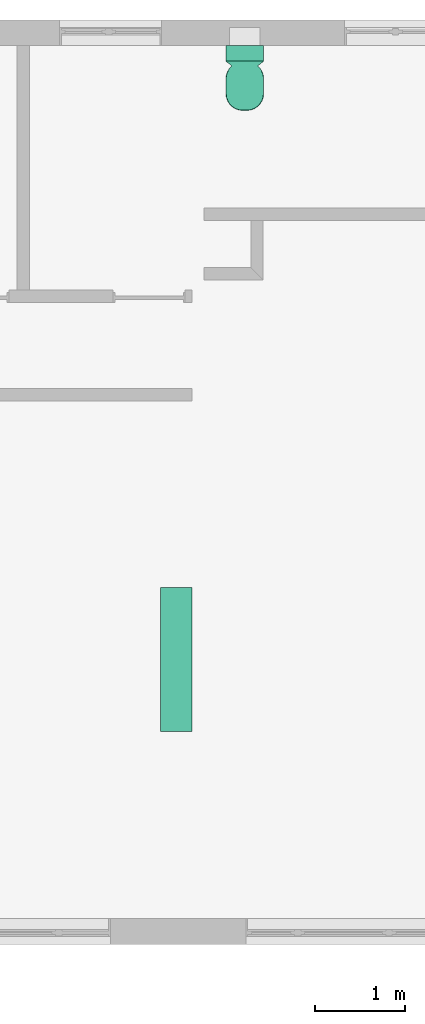
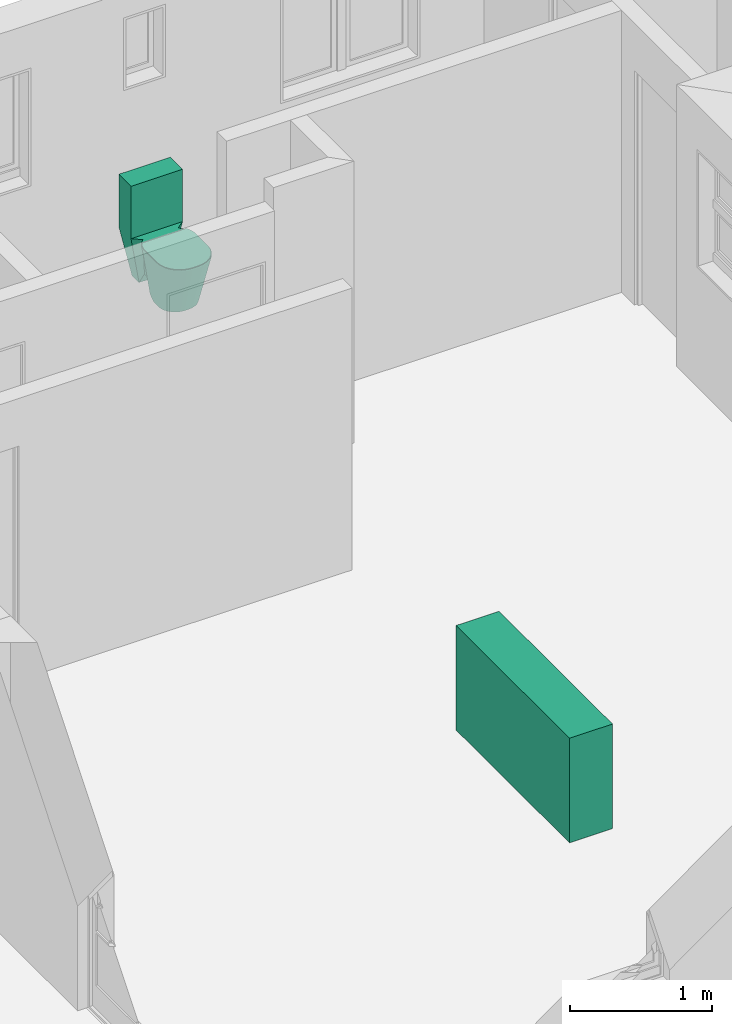
# One storey, part 15 of 15: 1 sanitary terminal, 1 space heater.
"""IFC4 building model written with IfcOpenShell, lengths in millimetres."""

from ifc_helpers import new_model, entity, si_unit, converted_unit, frame, origin_with_axes, origin_2d_with_axis, place, context, subcontext, project, spatial, polygons, source, transform, mapped, type_object, type_shapes, element, save


model = new_model("IFC4")

# Units and contexts
model_context = context("Model", 3, precision=1e-05, world=origin_with_axes())
plan_context = context("Plan", 2, precision=1e-05, world=origin_2d_with_axis())
body_context = subcontext(model_context, "Body", "Model", "MODEL_VIEW")
ifc_project = project(units=[si_unit("VOLUMEUNIT", "CUBIC_METRE"), si_unit("LENGTHUNIT", "METRE", prefix="MILLI"), converted_unit("PLANEANGLEUNIT", "degree", entity("IfcReal", 0.0174532925199433), si_unit("PLANEANGLEUNIT", "RADIAN"), dimensions=[0, 0, 0, 0, 0, 0, 0]), si_unit("AREAUNIT", "SQUARE_METRE")], contexts=[model_context, plan_context])

# Site, building, storey
site_placement = place(None, origin_with_axes())
site = spatial("IfcSite", under=ifc_project, at=site_placement)
building_placement = place(site_placement, origin_with_axes())
building = spatial("IfcBuilding", under=site, at=building_placement, Name="Building")
storey_placement = place(building_placement, origin_with_axes())
storey = spatial("IfcBuildingStorey", under=building, at=storey_placement, Name="EXISTING")

# Sanitary terminal
sanitary_terminal_type = type_object("IfcSanitaryTerminalType", Name="Toilet", PredefinedType="TOILETPAN")
shared_shape_1 = source(origin_with_axes(), body_context, "Body", "Tessellation", [
    polygons([(-123.31803894043, 324.464721679688, -214.999862670898), (-210.0, 360.0, 214.999984741211), (123.31803894043, 324.464721679688, -214.999862670898), (210.0, 360.0, 214.999984741211), (-123.31803894043, 223.359252929688, -214.999435424805), (-210.0, 187.826080322266, 214.999984741211), (123.31803894043, 223.359252929688, -214.999862670898), (210.0, 187.826080322266, 214.999984741211), (-154.309646606445, -91.084358215332, -214.999984741211), (210.0, -163.151611328125, 214.999984741211), (-210.0, -163.151611328125, 214.999984741211), (154.309646606445, -91.084358215332, -214.999984741211), (-143.305480957031, 135.49870300293, 214.999984741211), (104.407829284668, 180.682067871094, -121.331802368164), (-104.408195495605, 180.682083129883, -121.331802368164), (143.304977416992, 135.498718261719, 214.999984741211), (-16.6275787353516, -235.730102539062, -214.999984741211), (-154.309646606445, -98.0479965209961, -214.999984741211), (-47.264720916748, -232.278121948242, -214.999984741211), (-76.365592956543, -222.095291137695, -214.999984741211), (-102.470947265625, -205.692199707031, -214.999984741211), (-124.271766662598, -183.891403198242, -214.999984741211), (-140.674835205078, -157.786010742188, -214.999984741211), (-150.857681274414, -128.685165405273, -214.999984741211), (-210.0, -172.628433227539, 214.999984741211), (-22.6284408569336, -360.0, 214.999984741211), (-205.302200317383, -214.322555541992, 214.999984741211), (-191.444366455078, -253.925903320312, 214.999984741211), (-169.12141418457, -289.452728271484, 214.999984741211), (-139.452682495117, -319.121429443359, 214.999984741211), (-103.925910949707, -341.444396972656, 214.999984741211), (-64.3225326538086, -355.302185058594, 214.999984741211), (154.309646606445, -98.0479965209961, -214.999984741211), (16.627555847168, -235.730102539062, -214.999984741211), (150.857681274414, -128.685165405273, -214.999984741211), (140.674835205078, -157.786010742188, -214.999984741211), (124.271759033203, -183.891403198242, -214.999984741211), (102.470932006836, -205.692199707031, -214.999984741211), (76.3655776977539, -222.095291137695, -214.999984741211), (47.264705657959, -232.278121948242, -214.999984741211), (22.6284694671631, -360.0, 214.999984741211), (210.0, -172.628433227539, 214.999984741211), (64.3225555419922, -355.302185058594, 214.999984741211), (103.925918579102, -341.444396972656, 214.999984741211), (139.452697753906, -319.121429443359, 214.999984741211), (169.121429443359, -289.452728271484, 214.999984741211), (191.444366455078, -253.925903320312, 214.999984741211), (205.302200317383, -214.322555541992, 214.999984741211), (-154.309646606445, -36.9600563049316, -214.999984741211), (-104.70548248291, 142.322677612305, -121.334297180176), (-69.9907455444336, 83.1664428710938, -150.48860168457), (-151.592681884766, 18.9604740142822, -182.336196899414), (-145.59130859375, 40.6167221069336, -160.335861206055), (-133.410614013672, 62.7893905639648, -140.107452392578), (-122.13614654541, 84.3662490844727, -130.550598144531), (-114.744720458984, 104.265563964844, -126.247489929199), (-109.116271972656, 121.491508483887, -121.334510803223), (210.0, -1.09207618236542, 214.999984741211), (143.713348388672, 135.178298950195, 214.999984741211), (125.742744445801, 83.1651840209961, 214.999984741211), (208.338043212891, 18.9610080718994, 214.999984741211), (203.435562133789, 40.6166954040527, 214.999984741211), (195.538330078125, 62.7890930175781, 214.999984741211), (185.042404174805, 84.3663787841797, 214.999984741211), (172.474044799805, 104.266571044922, 214.999984741211), (158.463516235352, 121.491790771484, 214.999984741211), (-143.713516235352, 135.178527832031, 214.999984741211), (-210.0, -1.09206879138947, 214.999984741211), (-125.742744445801, 83.1651840209961, 214.999984741211), (-158.463638305664, 121.49195098877, 214.999984741211), (-172.47412109375, 104.266693115234, 214.999984741211), (-185.042449951172, 84.3664474487305, 214.999984741211), (-195.538360595703, 62.7891387939453, 214.999984741211), (-203.435562133789, 40.6167144775391, 214.999984741211), (-208.338043212891, 18.9610118865967, 214.999984741211), (104.705352783203, 142.322494506836, -121.334297180176), (154.309646606445, -36.9600563049316, -214.999984741211), (69.9907455444336, 83.1664428710938, -150.488479614258), (109.116180419922, 121.491363525391, -121.334716796875), (114.744651794434, 104.26545715332, -126.247817993164), (122.136108398438, 84.3661804199219, -130.550979614258), (133.410568237305, 62.7893486022949, -140.107788085938), (145.591293334961, 40.6166915893555, -160.336212158203), (151.592666625977, 18.9604682922363, -182.336318969727), (-210.0, 187.826080322266, 365.0), (-210.0, 360.0, 365.0), (210.0, 360.0, 365.0), (210.0, 187.826080322266, 365.0), (-210.0, 187.826080322266, 665.0), (-210.0, 360.0, 665.0), (210.0, 360.0, 665.0), (210.0, 187.826080322266, 665.0), (210.0, -163.151611328125, 214.999984741211), (-210.0, -163.151611328125, 214.999984741211), (-210.0, -172.628433227539, 214.999984741211), (-22.6284408569336, -360.0, 214.999984741211), (-205.302200317383, -214.322555541992, 214.999984741211), (-191.444366455078, -253.925903320312, 214.999984741211), (-169.12141418457, -289.452728271484, 214.999984741211), (-139.452682495117, -319.121429443359, 214.999984741211), (-103.925910949707, -341.444396972656, 214.999984741211), (-64.3225326538086, -355.302185058594, 214.999984741211), (22.6284694671631, -360.0, 214.999984741211), (210.0, -172.628433227539, 214.999984741211), (64.3225555419922, -355.302185058594, 214.999984741211), (103.925918579102, -341.444396972656, 214.999984741211), (139.452697753906, -319.121429443359, 214.999984741211), (169.121429443359, -289.452728271484, 214.999984741211), (191.444366455078, -253.925903320312, 214.999984741211), (205.302200317383, -214.322555541992, 214.999984741211), (210.0, -1.09207618236542, 214.999984741211), (125.742744445801, 83.1651840209961, 214.999984741211), (208.338043212891, 18.9610080718994, 214.999984741211), (203.435562133789, 40.6166954040527, 214.999984741211), (195.538330078125, 62.7890930175781, 214.999984741211), (185.042404174805, 84.3663787841797, 214.999984741211), (-210.0, -1.09206879138947, 214.999984741211), (-125.742744445801, 83.1651840209961, 214.999984741211), (-185.042449951172, 84.3664474487305, 214.999984741211), (-195.538360595703, 62.7891387939453, 214.999984741211), (-203.435562133789, 40.6167144775391, 214.999984741211), (-208.338043212891, 18.9610118865967, 214.999984741211), (125.742744445801, 83.1651840209961, 229.999984741211), (-125.742744445801, 83.1651840209961, 229.999984741211), (-204.148986816406, -163.151611328125, 229.999984741211), (-210.0, -163.151611328125, 224.788604736328), (-206.388061523438, -163.151611328125, 229.603286743164), (-208.286254882812, -163.151611328125, 228.473602294922), (-209.554595947266, -163.151611328125, 226.782913208008), (210.0, -163.151611328125, 224.788604736328), (204.148986816406, -163.151611328125, 229.999984741211), (209.554595947266, -163.151611328125, 226.782913208008), (208.286254882812, -163.151611328125, 228.473602294922), (206.388061523438, -163.151611328125, 229.603286743164), (-22.6284408569336, -360.0, 224.788604736328), (-22.3359031677246, -354.788604736328, 229.999984741211), (-22.6061744689941, -359.603332519531, 226.782913208008), (-22.5427589416504, -358.4736328125, 228.473602294922), (-22.4478530883789, -356.782958984375, 229.603286743164), (-63.1555137634277, -350.189331054688, 229.999984741211), (-64.3225326538086, -355.302185058594, 224.788604736328), (-63.602108001709, -352.145904541016, 229.603286743164), (-63.9807090759277, -353.804626464844, 228.473602294922), (-64.2337036132812, -354.912963867188, 226.782913208008), (-101.650497436523, -336.719360351562, 229.999984741211), (-103.925910949707, -341.444396972656, 224.788604736328), (-102.52124786377, -338.527526855469, 229.603286743164), (-103.25944519043, -340.060424804688, 228.473602294922), (-103.75267791748, -341.084686279297, 226.782913208008), (-136.182891845703, -315.021240234375, 229.999984741211), (-139.452682495117, -319.121429443359, 224.788604736328), (-137.434188842773, -316.590301513672, 229.603286743164), (-138.494995117188, -317.920501708984, 228.473602294922), (-139.203796386719, -318.809326171875, 226.782913208008), (-165.02116394043, -286.182952880859, 229.999984741211), (-169.12141418457, -289.452728271484, 224.788604736328), (-166.590255737305, -287.434234619141, 229.603286743164), (-167.920486450195, -288.495025634766, 228.473602294922), (-168.809310913086, -289.203796386719, 226.782913208008), (-186.719390869141, -251.650405883789, 229.999984741211), (-191.444366455078, -253.925903320312, 224.788604736328), (-188.527572631836, -252.521194458008, 229.603286743164), (-190.060485839844, -253.259429931641, 228.473602294922), (-191.084701538086, -253.752685546875, 226.782913208008), (-200.189331054688, -213.155578613281, 229.999984741211), (-205.302200317383, -214.322555541992, 224.788604736328), (-202.145919799805, -213.602157592773, 229.603286743164), (-203.804656982422, -213.980758666992, 228.473602294922), (-204.912994384766, -214.233734130859, 226.782913208008), (-204.173583984375, -177.794326782227, 229.999984741211), (-210.0, -172.628433227539, 224.788604736328), (-206.403259277344, -175.817413330078, 229.603286743164), (-208.293487548828, -174.141479492188, 228.473602294922), (-209.556488037109, -173.021667480469, 226.782913208008), (64.3225555419922, -355.302185058594, 224.788604736328), (63.1555366516113, -350.189331054688, 229.999984741211), (64.2337188720703, -354.912963867188, 226.782913208008), (63.9807395935059, -353.804626464844, 228.473602294922), (63.6021308898926, -352.145904541016, 229.603286743164), (22.3359317779541, -354.788604736328, 229.999984741211), (22.6284694671631, -360.0, 224.788604736328), (22.447883605957, -356.782958984375, 229.603286743164), (22.5427875518799, -358.4736328125, 228.473602294922), (22.6062030792236, -359.603332519531, 226.782913208008), (103.925918579102, -341.444396972656, 224.788604736328), (101.650512695312, -336.719360351562, 229.999984741211), (103.75269317627, -341.084686279297, 226.782913208008), (103.259460449219, -340.060424804688, 228.473602294922), (102.521263122559, -338.527526855469, 229.603286743164), (139.452697753906, -319.121429443359, 224.788604736328), (136.182876586914, -315.021270751953, 229.999984741211), (139.203811645508, -318.809326171875, 226.782913208008), (138.495010375977, -317.920532226562, 228.473602294922), (137.434204101562, -316.590362548828, 229.603286743164), (169.121429443359, -289.452728271484, 224.788604736328), (165.021179199219, -286.182952880859, 229.999984741211), (168.809310913086, -289.203796386719, 226.782913208008), (167.920471191406, -288.495025634766, 228.473602294922), (166.590255737305, -287.434204101562, 229.603286743164), (191.444366455078, -253.925903320312, 224.788604736328), (186.719390869141, -251.650405883789, 229.999984741211), (191.084701538086, -253.752685546875, 226.782913208008), (190.060470581055, -253.259429931641, 228.473602294922), (188.527572631836, -252.521194458008, 229.603286743164), (205.302200317383, -214.322555541992, 224.788604736328), (200.189331054688, -213.155578613281, 229.999984741211), (204.912994384766, -214.233734130859, 226.782913208008), (203.804656982422, -213.980758666992, 228.473602294922), (202.145919799805, -213.602157592773, 229.603286743164), (210.0, -172.628433227539, 224.788604736328), (204.173583984375, -177.794311523438, 229.999984741211), (209.556488037109, -173.021667480469, 226.782913208008), (208.293487548828, -174.141479492188, 228.473602294922), (206.403259277344, -175.817413330078, 229.603286743164), (204.073211669922, 4.83470773696899, 229.999984741211), (210.0, -1.09207618236542, 224.788604736328), (206.341278076172, 2.56662511825562, 229.603286743164), (208.264068603516, 0.643838107585907, 228.473602294922), (209.548843383789, -0.640928566455841, 226.782913208008), (208.338043212891, 18.9610080718994, 224.788604736328), (202.396835327148, 23.5793037414551, 229.999984741211), (207.885772705078, 19.3125667572021, 226.782913208008), (206.597885131836, 20.3136863708496, 228.473602294922), (204.67041015625, 21.8119735717773, 229.603286743164), (203.435562133789, 40.6166954040527, 224.788604736328), (197.683380126953, 43.7668800354004, 229.999984741211), (202.997695922852, 40.8564910888672, 226.782913208008), (201.750778198242, 41.5393676757812, 228.473602294922), (199.884643554688, 42.5613555908203, 229.603286743164), (195.538330078125, 62.7890930175781, 224.788604736328), (190.240310668945, 64.3357925415039, 229.999984741211), (195.135040283203, 62.9068260192871, 226.782913208008), (193.986587524414, 63.2421112060547, 228.473602294922), (192.267761230469, 63.7439002990723, 229.603286743164), (180.493515014648, 84.2742309570312, 229.999984741211), (185.042404174805, 84.3663787841797, 224.788604736328), (182.234298706055, 84.3095016479492, 229.603286743164), (183.710067749023, 84.3393936157227, 228.473602294922), (184.696136474609, 84.3593673706055, 226.782913208008), (-185.042449951172, 84.3664474487305, 224.788604736328), (-180.493545532227, 84.274299621582, 229.999984741211), (-184.696197509766, 84.3594360351562, 226.782913208008), (-183.710113525391, 84.3394622802734, 228.473602294922), (-182.234344482422, 84.3095626831055, 229.603286743164), (-195.538360595703, 62.7891387939453, 224.788604736328), (-190.240341186523, 64.3358306884766, 229.999984741211), (-195.135070800781, 62.9068717956543, 226.782913208008), (-193.986618041992, 63.2421569824219, 228.473602294922), (-192.267807006836, 63.7439384460449, 229.603286743164), (-203.435562133789, 40.6167144775391, 224.788604736328), (-197.683380126953, 43.7668952941895, 229.999984741211), (-202.997695922852, 40.856502532959, 226.782913208008), (-201.750778198242, 41.5393829345703, 228.473602294922), (-199.884643554688, 42.5613708496094, 229.603286743164), (-208.338043212891, 18.9610118865967, 224.788604736328), (-202.396835327148, 23.5793056488037, 229.999984741211), (-207.885772705078, 19.3125705718994, 226.782913208008), (-206.597885131836, 20.3136901855469, 228.473602294922), (-204.67041015625, 21.811975479126, 229.603286743164), (-210.0, -1.09206879138947, 224.788604736328), (-204.073211669922, 4.83471250534058, 229.999984741211), (-209.548843383789, -0.640921592712402, 226.782913208008), (-208.264068603516, 0.643844723701477, 228.473602294922), (-206.341278076172, 2.56663155555725, 229.603286743164)], [[[5, 6, 2, 1]], [[1, 2, 4, 3]], [[9, 12, 33, 35, 36, 37, 38, 39, 40, 34, 17, 19, 20, 21, 22, 23, 24, 18]], [[10, 11, 25, 27, 28, 29, 30, 31, 32, 26, 41, 43, 44, 45, 46, 47, 48, 42]], [[12, 10, 42, 33]], [[6, 8, 88, 85]], [[1, 3, 7, 5]], [[3, 4, 8, 7]], [[15, 6, 5]], [[78, 51, 50]], [[58, 60, 69, 68, 11, 10]], [[16, 76, 14]], [[77, 58, 10, 12]], [[34, 41, 26, 17]], [[9, 11, 68, 49]], [[16, 13, 67, 69, 60, 59]], [[8, 14, 7]], [[5, 7, 14, 15]], [[8, 6, 13, 16]], [[77, 12, 9]], [[17, 26, 32, 19]], [[19, 32, 31, 20]], [[20, 31, 30, 21]], [[21, 30, 29, 22]], [[22, 29, 28, 23]], [[23, 28, 27, 24]], [[24, 27, 25, 18]], [[41, 34, 40, 43]], [[43, 40, 39, 44]], [[44, 39, 38, 45]], [[45, 38, 37, 46]], [[46, 37, 36, 47]], [[47, 36, 35, 48]], [[48, 35, 33, 42]], [[18, 25, 11, 9]], [[49, 52, 51]], [[52, 53, 51]], [[53, 54, 51]], [[54, 55, 51]], [[55, 56, 51]], [[56, 57, 51]], [[57, 50, 51]], [[58, 61, 60]], [[61, 62, 60]], [[62, 63, 60]], [[63, 64, 60]], [[64, 65, 60]], [[65, 66, 60]], [[66, 59, 60]], [[67, 70, 69]], [[70, 71, 69]], [[71, 72, 69]], [[72, 73, 69]], [[73, 74, 69]], [[74, 75, 69]], [[75, 68, 69]], [[76, 79, 78]], [[79, 80, 78]], [[80, 81, 78]], [[81, 82, 78]], [[82, 83, 78]], [[83, 84, 78]], [[84, 77, 78]], [[67, 57, 70]], [[57, 71, 70]], [[56, 72, 71]], [[55, 73, 72]], [[54, 74, 73]], [[53, 75, 74]], [[52, 68, 75]], [[58, 84, 61]], [[61, 83, 62]], [[62, 82, 63]], [[63, 81, 64]], [[64, 80, 65]], [[65, 79, 66]], [[79, 59, 66]], [[50, 13, 15]], [[88, 87, 91, 92]], [[2, 6, 85, 86]], [[8, 4, 87, 88]], [[4, 2, 86, 87]], [[91, 90, 89, 92]], [[86, 85, 89, 90]], [[85, 88, 92, 89]], [[87, 86, 90, 91]], [[93, 104, 110, 109, 108, 107, 106, 105, 103, 96, 102, 101, 100, 99, 98, 97, 95, 94]], [[111, 93, 94, 117, 118, 112]], [[111, 112, 113]], [[113, 112, 114]], [[114, 112, 115]], [[115, 112, 116]], [[119, 118, 120]], [[120, 118, 121]], [[121, 118, 122]], [[122, 118, 117]], [[117, 94, 126, 260]], [[131, 125, 170, 165, 160, 155, 150, 145, 140, 136, 180, 176, 186, 191, 196, 201, 206, 211]], [[111, 113, 220, 216]], [[114, 115, 230, 225]], [[115, 116, 236, 230]], [[116, 112, 123, 235, 237, 238, 239, 236]], [[118, 119, 240, 242, 243, 244, 241, 124]], [[121, 122, 255, 250]], [[122, 117, 260, 255]], [[113, 114, 225, 220]], [[95, 97, 166, 171]], [[221, 226, 123]], [[103, 105, 175, 181]], [[226, 231, 123]], [[105, 106, 185, 175]], [[231, 235, 123]], [[106, 107, 190, 185]], [[94, 95, 171, 126]], [[107, 108, 195, 190]], [[102, 96, 135, 141]], [[108, 109, 200, 195]], [[112, 118, 124, 123]], [[109, 110, 205, 200]], [[119, 120, 245, 240]], [[110, 104, 210, 205]], [[241, 246, 124]], [[215, 221, 123]], [[96, 103, 181, 135]], [[246, 251, 124]], [[104, 93, 130, 210]], [[100, 101, 146, 151]], [[251, 256, 124]], [[101, 102, 141, 146]], [[99, 100, 151, 156]], [[256, 261, 124]], [[93, 111, 216, 130]], [[98, 99, 156, 161]], [[97, 98, 161, 166]], [[120, 121, 250, 245]], [[136, 140, 142, 139]], [[139, 142, 143, 138]], [[138, 143, 144, 137]], [[137, 144, 141, 135]], [[140, 145, 147, 142]], [[142, 147, 148, 143]], [[143, 148, 149, 144]], [[144, 149, 146, 141]], [[145, 150, 152, 147]], [[147, 152, 153, 148]], [[148, 153, 154, 149]], [[149, 154, 151, 146]], [[150, 155, 157, 152]], [[152, 157, 158, 153]], [[153, 158, 159, 154]], [[154, 159, 156, 151]], [[155, 160, 162, 157]], [[157, 162, 163, 158]], [[158, 163, 164, 159]], [[159, 164, 161, 156]], [[160, 165, 167, 162]], [[162, 167, 168, 163]], [[163, 168, 169, 164]], [[164, 169, 166, 161]], [[165, 170, 172, 167]], [[167, 172, 173, 168]], [[168, 173, 174, 169]], [[169, 174, 171, 166]], [[176, 180, 182, 179]], [[179, 182, 183, 178]], [[178, 183, 184, 177]], [[177, 184, 181, 175]], [[186, 176, 179, 189]], [[189, 179, 178, 188]], [[188, 178, 177, 187]], [[187, 177, 175, 185]], [[191, 186, 189, 194]], [[194, 189, 188, 193]], [[193, 188, 187, 192]], [[192, 187, 185, 190]], [[196, 191, 194, 199]], [[199, 194, 193, 198]], [[198, 193, 192, 197]], [[197, 192, 190, 195]], [[201, 196, 199, 204]], [[204, 199, 198, 203]], [[203, 198, 197, 202]], [[202, 197, 195, 200]], [[206, 201, 204, 209]], [[209, 204, 203, 208]], [[208, 203, 202, 207]], [[207, 202, 200, 205]], [[211, 206, 209, 214]], [[214, 209, 208, 213]], [[213, 208, 207, 212]], [[212, 207, 205, 210]], [[170, 125, 127, 172]], [[127, 173, 172]], [[128, 174, 173]], [[174, 129, 126, 171]], [[180, 136, 139, 182]], [[182, 139, 138, 183]], [[183, 138, 137, 184]], [[184, 137, 135, 181]], [[210, 130, 132, 212]], [[212, 133, 213]], [[213, 134, 214]], [[214, 134, 131, 211]], [[220, 219, 216]], [[222, 218, 219]], [[223, 217, 218]], [[224, 215, 217]], [[225, 222, 220]], [[227, 223, 222]], [[228, 224, 223]], [[229, 221, 224]], [[230, 227, 225]], [[232, 228, 227]], [[233, 229, 228]], [[234, 226, 229]], [[236, 232, 230]], [[239, 233, 232]], [[238, 234, 233]], [[237, 231, 234]], [[240, 247, 242]], [[242, 248, 243]], [[243, 249, 244]], [[244, 246, 241]], [[245, 252, 247]], [[247, 253, 248]], [[248, 254, 249]], [[249, 251, 246]], [[250, 257, 252]], [[252, 258, 253]], [[253, 259, 254]], [[254, 256, 251]], [[255, 262, 257]], [[257, 263, 258]], [[258, 264, 259]], [[259, 261, 256]], [[125, 264, 127]], [[127, 263, 128]], [[128, 262, 129]], [[129, 260, 126]], [[131, 217, 215]], [[134, 218, 217]], [[133, 219, 218]], [[132, 216, 219]], [[215, 123, 124, 261, 125, 131]], [[15, 13, 6]], [[50, 15, 14]], [[14, 76, 50]], [[76, 78, 50]], [[16, 59, 76]], [[8, 16, 14]], [[9, 49, 77]], [[49, 51, 77]], [[51, 78, 77]], [[67, 50, 57]], [[57, 56, 71]], [[56, 55, 72]], [[55, 54, 73]], [[54, 53, 74]], [[53, 52, 75]], [[52, 49, 68]], [[58, 77, 84]], [[61, 84, 83]], [[62, 83, 82]], [[63, 82, 81]], [[64, 81, 80]], [[65, 80, 79]], [[79, 76, 59]], [[50, 67, 13]], [[127, 128, 173]], [[128, 129, 174]], [[212, 132, 133]], [[213, 133, 134]], [[220, 222, 219]], [[222, 223, 218]], [[223, 224, 217]], [[224, 221, 215]], [[225, 227, 222]], [[227, 228, 223]], [[228, 229, 224]], [[229, 226, 221]], [[230, 232, 227]], [[232, 233, 228]], [[233, 234, 229]], [[234, 231, 226]], [[236, 239, 232]], [[239, 238, 233]], [[238, 237, 234]], [[237, 235, 231]], [[240, 245, 247]], [[242, 247, 248]], [[243, 248, 249]], [[244, 249, 246]], [[245, 250, 252]], [[247, 252, 253]], [[248, 253, 254]], [[249, 254, 251]], [[250, 255, 257]], [[252, 257, 258]], [[253, 258, 259]], [[254, 259, 256]], [[255, 260, 262]], [[257, 262, 263]], [[258, 263, 264]], [[259, 264, 261]], [[125, 261, 264]], [[127, 264, 263]], [[128, 263, 262]], [[129, 262, 260]], [[131, 134, 217]], [[134, 133, 218]], [[133, 132, 219]], [[132, 130, 216]]], closed=True),
])
type_shapes(sanitary_terminal_type, [shared_shape_1])
sanitary_terminal_placement = place(storey_placement, frame((10567.120552063, 5101.66788101196, 215.000033378601), z_axis=(0.0, 0.0, 1.0), x_axis=(1.0, 0.0, 0.0)))
element("IfcSanitaryTerminal", 1, at=sanitary_terminal_placement, inside=storey, type_object=sanitary_terminal_type, Name="SanitaryTerminal", context=body_context, shape_type="MappedRepresentation", body=[
    mapped(shared_shape_1, transform((0.0, 0.0, 0.0), x_axis=(1.0, 0.0, 0.0), y_axis=(0.0, 1.0, 0.0), z_axis=(0.0, 0.0, 1.0), scale=1.0)),
])

# Space heater
space_heater_type = type_object("IfcSpaceHeaterType", Name="ExistingHeater", PredefinedType="USERDEFINED")
shared_shape_2 = source(origin_with_axes(), body_context, "Body", "Tessellation", [
    polygons([(-175.0, -799.999938964844, -450.0), (-175.0, -799.999938964844, 450.0), (-175.0, 799.999938964844, -450.0), (-175.0, 799.999938964844, 450.0), (175.0, -799.999938964844, -450.0), (175.0, -799.999938964844, 450.0), (175.0, 799.999938964844, -450.0), (175.0, 799.999938964844, 450.0)], [[[1, 2, 4, 3]], [[3, 4, 8, 7]], [[7, 8, 6, 5]], [[5, 6, 2, 1]], [[3, 7, 5, 1]], [[8, 4, 2, 6]]], closed=True),
])
type_shapes(space_heater_type, [shared_shape_2])
space_heater_placement = place(storey_placement, frame((9804.12292480469, -1353.33263874054, 450.000017881393), z_axis=(0.0, 0.0, 1.0), x_axis=(1.0, 0.0, 0.0)))
element("IfcSpaceHeater", 2, at=space_heater_placement, inside=storey, type_object=space_heater_type, Name="SpaceHeater", context=body_context, shape_type="MappedRepresentation", body=[
    mapped(shared_shape_2, transform((0.0, 0.0, 0.0), x_axis=(1.0, 0.0, 0.0), y_axis=(0.0, 1.0, 0.0), z_axis=(0.0, 0.0, 1.0), scale=1.0)),
])

save(model, "model.ifc")
